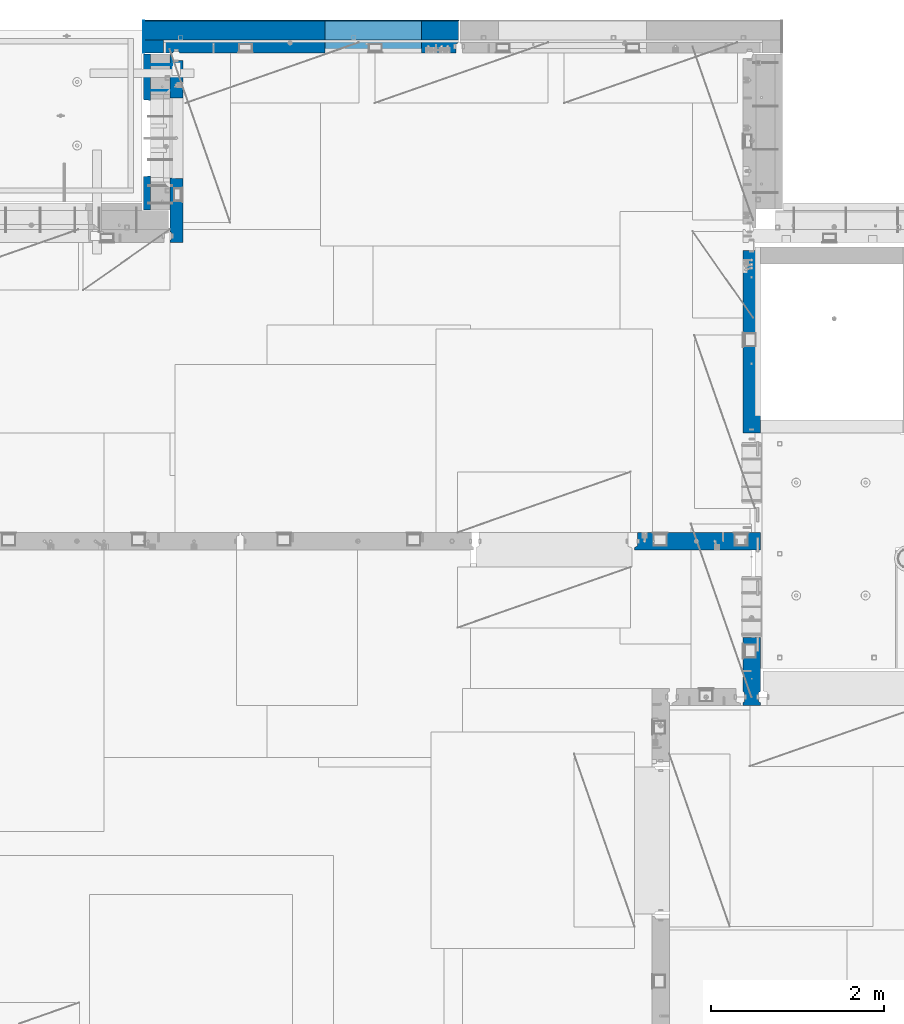
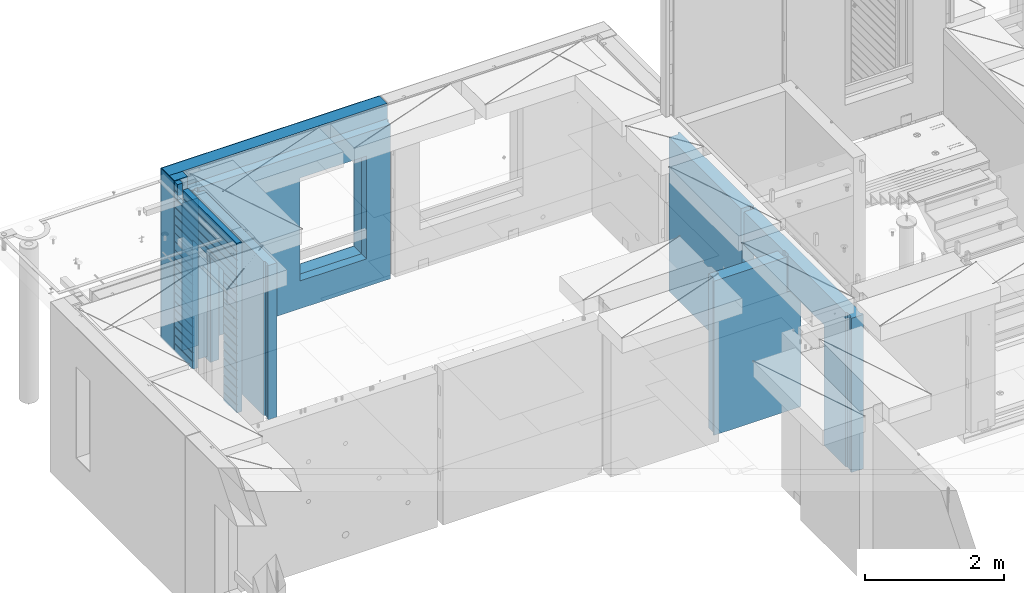
# One storey, part 237 of 352: 12 walls, 5 elements without a shape of their own.
"""IFC2X3 building model written with IfcOpenShell, lengths in millimetres."""

import ifcopenshell
import ifcopenshell.guid

model = None  # the IFC model being written
_history = None  # IfcOwnerHistory: only IFC2X3 demands one
_inside = {}  # id of a spatial element -> (the spatial element, [elements in it])
_under = {}  # id of a project, library or spatial element -> (it, [spatial elements below it])
_declared = {}  # id of a project -> (the project, [libraries it declares])
_typed = {}  # id of a type object -> (the type object, [elements of that type])
_made_of = {}  # id of a material, layer set ... -> (it, [elements and type objects made of it])


def new_model(schema):
    """Start an empty IFC model of exactly this schema.

    Asked for "IFC4X3", IfcOpenShell would pick the latest addendum, in which some entities
    have other attributes; the version numbers below select the first issue.
    IFC2X3 requires an IfcOwnerHistory on every rooted entity: one is made here for all.
    """
    global model, _history
    if schema == "IFC4X3":
        model = ifcopenshell.file(schema_version=(4, 3, 0, 0))
    else:
        model = ifcopenshell.file(schema=schema)
    _inside.clear()
    _under.clear()
    _declared.clear()
    _typed.clear()
    _made_of.clear()
    _history = None
    if model.schema == "IFC2X3":
        org = make("IfcOrganization", Name="unknown")
        user = make(
            "IfcPersonAndOrganization",
            ThePerson=make("IfcPerson", FamilyName="unknown"),
            TheOrganization=org,
        )
        app = make(
            "IfcApplication",
            ApplicationDeveloper=org,
            Version="unknown",
            ApplicationFullName="unknown",
            ApplicationIdentifier="unknown",
        )
        _history = make(
            "IfcOwnerHistory",
            OwningUser=user,
            OwningApplication=app,
            ChangeAction="ADDED",
            CreationDate=0,
        )
    return model


def make(cls, **values):
    """One entity of the class cls with the attributes given. An attribute that is None is left unset."""
    return model.create_entity(
        cls, **{name: value for name, value in values.items() if value is not None}
    )


def rooted(cls, **values):
    """An entity with a GlobalId (a new one), such as an element, a storey or a relation."""
    return make(cls, GlobalId=ifcopenshell.guid.new(), OwnerHistory=_history, **values)


def si_unit(unit_type, name, prefix=None):
    """IfcSIUnit, for example si_unit("LENGTHUNIT", "METRE", prefix="MILLI")."""
    return make("IfcSIUnit", UnitType=unit_type, Prefix=prefix, Name=name)


def assignment(units):
    """IfcUnitAssignment: the units of a project."""
    return None if units is None else make("IfcUnitAssignment", Units=units)


def point(xyz):
    """IfcCartesianPoint."""
    return None if xyz is None else make("IfcCartesianPoint", Coordinates=xyz)


def direction(xyz):
    """IfcDirection."""
    return None if xyz is None else make("IfcDirection", DirectionRatios=xyz)


def frame(location, z_axis=None, x_axis=None):
    """IfcAxis2Placement3D, a coordinate frame: its origin and axes. An axis left out is left unset."""
    return make(
        "IfcAxis2Placement3D",
        Location=point(location),
        Axis=direction(z_axis),
        RefDirection=direction(x_axis),
    )


def origin_with_axes():
    """The frame at (0, 0, 0) with the z axis (0, 0, 1) and the x axis (1, 0, 0) written out."""
    return frame((0.0, 0.0, 0.0), z_axis=(0.0, 0.0, 1.0), x_axis=(1.0, 0.0, 0.0))


def place(relative_to, where):
    """IfcLocalPlacement: puts the frame where relative to a parent placement (None: the world)."""
    return make(
        "IfcLocalPlacement", PlacementRelTo=relative_to, RelativePlacement=where
    )


def context(
    kind, dimensions, precision=None, world=None, true_north=None, identifier=None
):
    """IfcGeometricRepresentationContext, for example the 3D "Model" context."""
    return make(
        "IfcGeometricRepresentationContext",
        ContextIdentifier=identifier,
        ContextType=kind,
        CoordinateSpaceDimension=dimensions,
        Precision=precision,
        WorldCoordinateSystem=world,
        TrueNorth=true_north,
    )


def subcontext(parent, identifier, kind, view, scale=None):
    """IfcGeometricRepresentationSubContext, for example "Body" below "Model"."""
    return make(
        "IfcGeometricRepresentationSubContext",
        ContextIdentifier=identifier,
        ContextType=kind,
        ParentContext=parent,
        TargetScale=scale,
        TargetView=view,
    )


def project(units=None, contexts=None):
    """IfcProject with its units and contexts."""
    return rooted(
        "IfcProject",
        Name="project",
        RepresentationContexts=contexts,
        UnitsInContext=assignment(units),
    )


def spatial(cls, under=None, at=None, **own):
    """A site, building, storey or space (cls), placed at a placement, below another one or the project."""
    s = rooted(cls, ObjectPlacement=at, **own)
    if under is not None:
        _under.setdefault(under.id(), (under, []))[1].append(s)
    return s


def faces_of(points, faces, orient=None, outer=None):
    """IfcFace entities. A face is a list of loops; a loop is a list of indices into points, from 0.

    orient and outer hold one flag for each loop. By default every Orientation is true, the
    first loop of a face is its IfcFaceOuterBound and the others are IfcFaceBound.
    """
    made = []
    for i, loops in enumerate(faces):
        bounds = []
        for j, loop in enumerate(loops):
            is_outer = j == 0 if outer is None else outer[i][j]
            bounds.append(
                make(
                    "IfcFaceOuterBound" if is_outer else "IfcFaceBound",
                    Bound=make("IfcPolyLoop", Polygon=[points[k] for k in loop]),
                    Orientation=True if orient is None else orient[i][j],
                )
            )
        made.append(make("IfcFace", Bounds=bounds))
    return made


def faceted_brep(points, faces, orient=None, outer=None, voids=None):
    """IfcFacetedBrep: a solid bounded by flat faces; with voids (closed shells), ...WithVoids."""
    shared = [point(p) for p in points]
    hull = make("IfcClosedShell", CfsFaces=faces_of(shared, faces, orient, outer))
    if voids is None:
        return make("IfcFacetedBrep", Outer=hull)
    return make(
        "IfcFacetedBrepWithVoids",
        Outer=hull,
        Voids=[
            make(cls, CfsFaces=faces_of(shared, fs, o, b)) for cls, fs, o, b in voids
        ],
    )


def shape(context_of_items, identifier, shape_type, items):
    """IfcShapeRepresentation: the items that make up one representation, for example the "Body"."""
    return make(
        "IfcShapeRepresentation",
        ContextOfItems=context_of_items,
        RepresentationIdentifier=identifier,
        RepresentationType=shape_type,
        Items=items,
    )


def material(Name=None, Category=None):
    """IfcMaterial."""
    return make("IfcMaterial", Name=Name, Category=Category)


def made_of(thing, what):
    """Note that an element or type object is made of a material, layer set ...; save() writes the relation."""
    if what is not None:
        _made_of.setdefault(what.id(), (what, []))[1].append(thing)
    return thing


def type_object(cls, material=None, **own):
    """A type object (cls), such as IfcWallType, which elements share."""
    return made_of(rooted(cls, **own), material)


def element(
    cls,
    number,
    at=None,
    inside=None,
    cuts=None,
    type_object=None,
    material=None,
    context=None,
    identifier="Body",
    shape_type=None,
    held_by="IfcProductDefinitionShape",
    body=None,
    shapes=None,
    **own,
):
    """One element of the class cls, such as IfcWall. Its Tag is "e" and its number.

    at: its placement. inside: the storey or other place that contains it. cuts: it is an
    opening in that element (IfcRelVoidsElement). A single representation is given by context,
    identifier, shape_type and body (its items); several are given by shapes. held_by: the class
    of the entity that holds the representations. save() writes the other relations.
    """
    e = rooted(cls, Tag="e%d" % number, ObjectPlacement=at, **own)
    if body is not None:
        shapes = [shape(context, identifier, shape_type, body)]
    if shapes is not None:
        e.Representation = make(held_by, Representations=shapes)
    if inside is not None:
        _inside.setdefault(inside.id(), (inside, []))[1].append(e)
    if cuts is not None:
        rooted(
            "IfcRelVoidsElement", RelatingBuildingElement=cuts, RelatedOpeningElement=e
        )
    if type_object is not None:
        _typed.setdefault(type_object.id(), (type_object, []))[1].append(e)
    return made_of(e, material)


def aggregate(whole, parts):
    """IfcRelAggregates: a whole, such as a stair, and the parts it consists of."""
    return rooted("IfcRelAggregates", RelatingObject=whole, RelatedObjects=parts)


def save(model, path):
    """Write the relations noted so far, then the file.

    IfcRelAggregates (storeys below a building ...), IfcRelContainedInSpatialStructure (elements
    in a storey), IfcRelDefinesByType, IfcRelAssociatesMaterial and IfcRelDeclares: one each for
    every whole, place, type object, material and project.
    """
    for whole, parts in _under.values():
        aggregate(whole, parts)
    for where, things in _inside.values():
        rooted(
            "IfcRelContainedInSpatialStructure",
            RelatedElements=things,
            RelatingStructure=where,
        )
    for kind, things in _typed.values():
        rooted("IfcRelDefinesByType", RelatedObjects=things, RelatingType=kind)
    for what, things in _made_of.values():
        rooted("IfcRelAssociatesMaterial", RelatedObjects=things, RelatingMaterial=what)
    for by, libraries in _declared.values():
        rooted("IfcRelDeclares", RelatingContext=by, RelatedDefinitions=libraries)
    model.write(path)


model = new_model("IFC2X3")

# Units and contexts
model_context = context("Model", 3, precision=1e-05, world=origin_with_axes())
body_context = subcontext(model_context, "Body", "Model", "MODEL_VIEW")
ifc_project = project(units=[si_unit("LENGTHUNIT", "METRE", prefix="MILLI"), si_unit("AREAUNIT", "SQUARE_METRE"), si_unit("VOLUMEUNIT", "CUBIC_METRE"), si_unit("MASSUNIT", "GRAM", prefix="KILO"), si_unit("TIMEUNIT", "SECOND"), si_unit("PLANEANGLEUNIT", "RADIAN"), si_unit("SOLIDANGLEUNIT", "STERADIAN"), si_unit("THERMODYNAMICTEMPERATUREUNIT", "DEGREE_CELSIUS"), si_unit("LUMINOUSINTENSITYUNIT", "LUMEN")], contexts=[model_context])

# Site, building, storey
site_placement = place(None, origin_with_axes())
site = spatial("IfcSite", under=ifc_project, at=site_placement, CompositionType="ELEMENT")
building_placement = place(site_placement, origin_with_axes())
building = spatial("IfcBuilding", under=site, at=building_placement, CompositionType="ELEMENT")
storey_placement = place(building_placement, origin_with_axes())
storey = spatial("IfcBuildingStorey", under=building, at=storey_placement, Name="6", CompositionType="ELEMENT", Elevation=0.0)

# Assembly, walls
assembly_1_placement = place(storey_placement, origin_with_axes())
assembly_1 = element("IfcElementAssembly", 1, at=assembly_1_placement, inside=storey, AssemblyPlace="NOTDEFINED", PredefinedType="REINFORCEMENT_UNIT")
ifc_material_1 = material(Name="Undefined")
wall_type_1 = type_object("IfcWallType", PredefinedType="NOTDEFINED")
wall_1_placement = place(assembly_1_placement, frame((11020.0, 22485.0002441406, 98115.0), z_axis=(0.0, 0.0, 1.0), x_axis=(-1.0, 3.00000001838171e-08, 0.0)))
wall_1 = element("IfcWall", 2, at=wall_1_placement, type_object=wall_type_1, material=ifc_material_1, Name="(PD)", context=body_context, shape_type="Brep", body=[
    faceted_brep([(0.0, 5.0, -1300.0), (0.0, 5.0, 1300.0), (280.0, 5.0, 1300.0), (280.0, 5.0, -1300.0), (0.0, -5.0, 1300.0), (280.0, -5.0, 1300.0), (0.0, -5.0, -1300.0), (280.0, -5.0, -1300.0)], [[[0, 1, 2, 3]], [[1, 4, 5, 2]], [[4, 6, 7, 5]], [[6, 0, 3, 7]], [[5, 7, 3, 2]], [[6, 4, 1, 0]]]),
])
wall_2_placement = place(assembly_1_placement, frame((11020.0, 22185.0002441406, 98115.0), z_axis=(0.0, 0.0, 1.0), x_axis=(-1.0, 3.00000001838171e-08, 0.0)))
wall_2 = element("IfcWall", 3, at=wall_2_placement, type_object=wall_type_1, material=ifc_material_1, Name="(PD)", context=body_context, shape_type="Brep", body=[
    faceted_brep([(0.0, 5.0, -1300.0), (0.0, 5.0, 1300.0), (280.0, 5.0, 1300.0), (280.0, 5.0, -1300.0), (0.0, -5.0, 1300.0), (280.0, -5.0, 1300.0), (0.0, -5.0, -1300.0), (280.0, -5.0, -1300.0)], [[[0, 1, 2, 3]], [[1, 4, 5, 2]], [[4, 6, 7, 5]], [[6, 0, 3, 7]], [[5, 7, 3, 2]], [[6, 4, 1, 0]]]),
])

# Assembly, wall
assembly_2_placement = place(storey_placement, origin_with_axes())
assembly_2 = element("IfcElementAssembly", 4, at=assembly_2_placement, inside=storey, AssemblyPlace="NOTDEFINED", PredefinedType="REINFORCEMENT_UNIT")
ifc_material_2 = material(Name="CONCRETE/C25/30")
wall_type_2 = type_object("IfcWallType", PredefinedType="NOTDEFINED")
wall_3_placement = place(assembly_2_placement, frame((17710.0, 18214.9992663657, 98112.5), z_axis=(0.0, 0.0, 1.0), x_axis=(0.0, 1.0, 0.0)))
wall_3 = element("IfcWall", 5, at=wall_3_placement, type_object=wall_type_2, material=ifc_material_2, context=body_context, shape_type="Brep", body=[
    faceted_brep([(2120.00073363433, -57.0000000000036, 1357.5), (2120.00073363433, -57.0000000000036, -1357.5), (2120.00073363433, 100.0, -1357.5), (2120.00073363433, 100.0, 1357.5), (2165.00073363433, -70.0000000000036, 1357.5), (2165.00073363433, -70.0000000000036, -1357.5), (45.0, 100.0, 1357.5), (45.0, 100.0, 762.5), (45.0, -57.0, 762.5), (45.0, -57.0, 1357.5), (15.0, -70.0, 762.5), (15.0, 100.0, 762.5), (15.0, -70.0, 1357.5), (15.0, 100.0, -1357.5), (15.0, -100.0, -1357.5), (15.0, -100.0, 1357.5), (2165.00073363433, -100.0, -1357.5), (2165.00073363433, -100.0, 1357.5)], [[[0, 1, 2, 3]], [[4, 5, 1, 0]], [[6, 7, 8, 9]], [[10, 8, 7, 11]], [[12, 9, 8, 10]], [[11, 13, 14, 15, 12, 10]], [[15, 14, 16, 17]], [[3, 6, 9, 12, 15, 17, 4, 0]], [[13, 11, 7, 6, 3, 2]], [[16, 14, 13, 2, 1, 5]], [[17, 16, 5, 4]]]),
])
aggregate(assembly_2, [wall_3])

assembly_3_placement = place(storey_placement, origin_with_axes())
assembly_3 = element("IfcElementAssembly", 6, at=assembly_3_placement, inside=storey, AssemblyPlace="NOTDEFINED", PredefinedType="REINFORCEMENT_UNIT")
wall_4_placement = place(assembly_3_placement, frame((17710.0, 15080.0, 98112.5), z_axis=(0.0, 0.0, 1.0), x_axis=(0.0, 1.0, 0.0)))
wall_4 = element("IfcWall", 7, at=wall_4_placement, type_object=wall_type_2, material=ifc_material_2, context=body_context, shape_type="Brep", body=[
    faceted_brep([(3089.99926636568, -57.0, 1357.5), (3089.99926636568, -57.0, 762.5), (3089.99926620436, 100.0, 762.5), (3089.99926636568, 100.0, 1357.5), (3119.99926636568, -70.0, 1357.5), (3119.99926636568, -69.9999995451544, 762.5), (1965.00000368528, 100.0, 1357.5), (1965.00000368528, 99.9999997455598, 762.5), (1951.9999991369, 80.0000000823711, 762.5), (1951.9999991369, 80.0000000823711, 1357.5), (1848.00000041054, 79.9999993903439, 762.5), (1848.00000041054, 79.9999993903439, 1357.5), (1835.0, 100.0, 762.5), (1835.0, 100.0, 1357.5), (790.003238525391, -100.0, -1357.5), (790.003238525391, 100.0, -1357.5), (790.003238525391, 100.0, 762.5), (790.003238525391, -100.0, 762.5), (164.999999999998, 100.0, -1357.5), (164.999999999996, 100.0, 1357.5), (47.9997742438973, -79.9991481948964, 1357.5), (47.9997742438991, -79.9991481948928, -1357.5), (152.000000457021, -79.9991466091124, -1357.5), (152.000000457019, -79.9991466091124, 1357.5), (34.9997701872417, -100.0, 1357.5), (34.9997701872435, -100.0, -1357.5), (0.0, -100.0, 1357.5), (0.0, -100.0, -1357.5), (0.0, 100.0, 1357.5), (0.0, 100.0, -1357.5), (35.0, 100.0, 1357.5), (35.0, 100.0, -1357.5), (48.0, 80.0, 1357.5), (48.0, 80.0, -1357.5), (152.0, 80.0, 1357.5), (152.0, 80.0, -1357.5), (165.0, -100.0, -1357.5), (164.999999999998, -99.9991455078125, 1357.5), (3119.99926636568, -100.0, 762.5), (3119.99926636568, -100.0, 1357.5)], [[[0, 1, 2, 3]], [[4, 5, 1, 0]], [[6, 7, 8, 9]], [[9, 8, 10, 11]], [[11, 10, 12, 13]], [[14, 15, 16, 17]], [[13, 12, 16, 15, 18, 19]], [[20, 21, 22, 23]], [[24, 25, 21, 20]], [[26, 27, 25, 24]], [[27, 26, 28, 29]], [[29, 28, 30, 31]], [[32, 33, 31, 30]], [[34, 35, 33, 32]], [[19, 18, 35, 34]], [[15, 14, 36, 22, 21, 25, 27, 29, 31, 33, 35, 18]], [[37, 23, 22, 36]], [[14, 17, 38, 39, 37, 36]], [[13, 19, 34, 32, 30, 28, 26, 24, 20, 23, 37, 39, 4, 0, 3, 6, 9, 11]], [[7, 6, 3, 2]], [[38, 17, 16, 12, 10, 8, 7, 2, 1, 5]], [[39, 38, 5, 4]]]),
])
aggregate(assembly_3, [wall_4])

assembly_4_placement = place(storey_placement, origin_with_axes())
assembly_4 = element("IfcElementAssembly", 8, at=assembly_4_placement, inside=storey, AssemblyPlace="NOTDEFINED", PredefinedType="REINFORCEMENT_UNIT")
wall_5_placement = place(assembly_4_placement, frame((16359.9991042544, 16980.0, 98112.5), z_axis=(0.0, 0.0, 1.0), x_axis=(1.0, 0.0, 0.0)))
wall_5 = element("IfcWall", 9, at=wall_5_placement, type_object=wall_type_2, material=ifc_material_2, context=body_context, shape_type="Brep", body=[
    faceted_brep([(1185.00089736511, 100.0, 1357.5), (1185.00089574558, -57.0, 1357.5), (1185.00089574558, -57.0, 742.5), (1185.00089736511, 99.9999999278843, 742.5), (1220.00089574558, -70.2708332915754, 1357.5), (1220.00089574558, -70.270833291579, 742.5), (1220.00089574558, 100.000001967095, 742.5), (0.0, -100.0, -1357.5), (0.0, -100.0, 1357.5), (0.0, -70.0000178764712, 1357.5), (0.0, -70.0000178764712, -1357.5), (30.0000412533973, -57.0, 1357.5), (30.0000412533973, -57.0, -1357.5), (30.0000000000009, 100.0, 1357.5), (30.0, 100.0, -1357.5), (1450.0, 100.0, -1357.5), (1450.0, -100.0, -1357.5), (1450.00089574558, 100.0, 742.5), (1450.0, -100.0, 742.5), (1220.00089574558, -100.0, 1357.5), (1220.00089574558, -100.0, 742.5), (1225.00089532057, 100.0, 742.5)], [[[0, 1, 2, 3]], [[4, 5, 2, 1]], [[6, 3, 2, 5]], [[7, 8, 9, 10]], [[11, 12, 10, 9]], [[13, 14, 12, 11]], [[15, 16, 7, 10, 12, 14]], [[16, 15, 17, 18]], [[19, 8, 7, 16, 18, 20]], [[17, 21, 6, 5, 20, 18]], [[19, 20, 5, 4]], [[0, 13, 11, 9, 8, 19, 4, 1]], [[21, 17, 15, 14, 13, 0, 3, 6]]]),
])
aggregate(assembly_4, [wall_5])

# Assembly, walls
assembly_5_placement = place(storey_placement, origin_with_axes())
assembly_5 = element("IfcElementAssembly", 10, at=assembly_5_placement, inside=storey, AssemblyPlace="NOTDEFINED", PredefinedType="REINFORCEMENT_UNIT")
ifc_material_3 = material()
wall_type_3 = type_object("IfcWallType", PredefinedType="NOTDEFINED")
wall_6_placement = place(assembly_5_placement, frame((10805.0, 22620.0, 98247.5), z_axis=(0.0, 0.0, 1.0), x_axis=(0.0, 1.0, 0.0)))
wall_6 = element("IfcWall", 11, at=wall_6_placement, type_object=wall_type_3, material=ifc_material_3, context=body_context, shape_type="Brep", body=[
    faceted_brep([(0.0, 110.0, -1492.5), (0.0, 110.0, 1492.5), (150.0, 110.0, 1492.5), (150.0, 110.0, -1492.5), (0.0, -110.0, 1492.5), (150.0, -110.0, 1492.5), (0.0, -110.0, -1492.5), (150.0, -110.0, -1492.5)], [[[0, 1, 2, 3]], [[1, 4, 5, 2]], [[4, 6, 7, 5]], [[6, 0, 3, 7]], [[5, 7, 3, 2]], [[6, 4, 1, 0]]]),
])
wall_7_placement = place(assembly_5_placement, frame((10915.0, 22880.0, 98247.5), z_axis=(0.0, 0.0, 1.0), x_axis=(1.0, 0.0, 0.0)))
wall_7 = element("IfcWall", 12, at=wall_7_placement, type_object=wall_type_3, material=ifc_material_3, context=body_context, shape_type="Brep", body=[
    faceted_brep([(-220.0, -110.0, -1492.5), (-220.0, 110.0, -1492.5), (3410.0, 110.0, -1492.5), (3410.0, -110.0, -1492.5), (-220.0, -110.0, 1492.5), (-220.0, 110.0, 1492.5), (3410.0, -110.0, 1492.5), (3410.0, 110.0, 1492.5), (1869.99971073172, 110.0, -1002.5), (2979.99971073172, 110.0, -1002.5), (2979.99971073172, 110.0, 807.5), (1869.99971073172, 110.0, 807.5), (1869.99971073172, -110.0, -1002.5), (1869.99971073172, -110.0, 807.5), (2979.99971073172, -110.0, 807.5), (2979.99971073172, -110.0, -1002.5)], [[[0, 1, 2, 3]], [[0, 4, 5, 1]], [[5, 4, 6, 7]], [[1, 5, 7, 2], [8, 9, 10, 11]], [[6, 3, 2, 7]], [[4, 0, 3, 6], [12, 13, 14, 15]], [[10, 14, 13, 11]], [[9, 15, 14, 10]], [[8, 12, 15, 9]], [[11, 13, 12, 8]]]),
])

# Wall
ifc_material_4 = material(Name="CONCRETE/C30/37")
wall_type_4 = type_object("IfcWallType", PredefinedType="NOTDEFINED")
wall_8_placement = place(assembly_1_placement, frame((10727.5, 20805.0, 98247.5), z_axis=(0.0, 0.0, 1.0), x_axis=(0.0, 1.0, 0.0)))
wall_8 = element("IfcWall", 13, at=wall_8_placement, type_object=wall_type_4, material=ifc_material_4, context=body_context, shape_type="Brep", body=[
    faceted_brep([(1800.0, -42.5, 1492.5), (1800.0, 42.5, 1492.5), (1705.0, 42.5, 1492.5), (1705.0, -42.5, 1492.5), (0.0, 42.5, -1492.5), (0.0, 42.5, -1357.00000005524), (384.998212827581, 42.5, -1357.00000005524), (384.998212827581, 42.5, -1492.5), (0.0, 32.4999992507037, -1355.00000000074), (386.174879582417, 32.4999992506928, -1355.0000000008), (0.0, 32.4999991127006, -1344.99999959956), (386.174879598653, 32.4999991126915, -1344.99999959957), (0.0, 42.5, -1343.00000011075), (384.998212827581, 42.5, -1343.00000011075), (0.0, 42.5, -1207.00000005524), (384.998212827581, 42.5, -1207.00000005524), (0.0, 32.4999992507037, -1205.00000000074), (386.174879582417, 32.4999992506928, -1205.0000000008), (0.0, 32.4999991127006, -1194.99999959956), (386.174879598653, 32.4999991126915, -1194.99999959957), (0.0, 42.5, -1193.00000011075), (384.998212827581, 42.5, -1193.00000011075), (0.0, 42.5, -1057.00000005524), (384.998212827581, 42.5, -1057.00000005524), (0.0, 32.4999992507037, -1055.00000000074), (386.174879582417, 32.4999992506928, -1055.0000000008), (0.0, 32.4999991127006, -1044.99999959956), (386.174879598653, 32.4999991126915, -1044.99999959957), (0.0, 42.5, -1043.00000011075), (384.998212827581, 42.5, -1043.00000011075), (0.0, 42.5, -907.000000055239), (384.998212827581, 42.5, -907.000000055239), (0.0, 32.4999992507037, -905.000000000742), (386.174879582417, 32.4999992506928, -905.0000000008), (0.0, 32.4999991127006, -894.99999959956), (386.174879598653, 32.4999991126915, -894.999999599575), (0.0, 42.5, -893.000000110755), (384.998212827581, 42.5, -893.000000110755), (0.0, 42.5, -757.000000055239), (384.998212827581, 42.5, -757.000000055239), (0.0, 32.4999992507037, -755.000000000742), (386.174879582417, 32.4999992506928, -755.0000000008), (0.0, 32.4999991127006, -744.99999959956), (386.174879598653, 32.4999991126915, -744.999999599575), (0.0, 42.5, -743.000000110755), (384.998212827581, 42.5, -743.000000110755), (0.0, 42.5, -607.000000055239), (384.998212827581, 42.5, -607.000000055239), (3.63797880709171e-12, 32.4999992507037, -605.000000000742), (386.174879582417, 32.4999992506928, -605.0000000008), (3.63797880709171e-12, 32.4999991127006, -594.99999959956), (386.174879598653, 32.4999991126915, -594.999999599575), (0.0, 42.5, -593.000000110755), (384.998212827581, 42.5, -593.000000110755), (0.0, 42.5, -457.000000055239), (384.998212827581, 42.5, -457.000000055239), (0.0, 32.4999992507037, -455.000000000742), (386.174879582417, 32.4999992506928, -455.0000000008), (0.0, 32.4999991127006, -444.99999959956), (386.174879598653, 32.4999991126915, -444.999999599575), (0.0, 42.5, -443.000000110755), (384.998212827581, 42.5, -443.000000110755), (0.0, 42.5, -307.000000055239), (384.998212827581, 42.5, -307.000000055239), (0.0, 32.4999992507037, -305.000000000742), (386.174879582417, 32.4999992506928, -305.0000000008), (0.0, 32.4999991127006, -294.99999959956), (386.174879598653, 32.4999991126915, -294.999999599575), (0.0, 42.5, -293.000000110755), (384.998212827581, 42.5, -293.000000110755), (0.0, 42.5, -157.000000055239), (384.998212827581, 42.5, -157.000000055239), (3.63797880709171e-12, 32.4999992507037, -155.000000000742), (386.174879582417, 32.4999992506928, -155.0000000008), (3.63797880709171e-12, 32.4999991127006, -144.99999959956), (386.174879598653, 32.4999991126915, -144.999999599575), (0.0, 42.5, -143.000000110755), (384.998212827581, 42.5, -143.000000110755), (0.0, 42.5, -7.00000005523907), (384.998212827581, 42.5, -7.00000005523907), (0.0, 32.4999992507037, -5.00000000074215), (386.174879582417, 32.4999992506928, -5.00000000080036), (0.0, 32.4999991127006, 5.0000004004396), (386.174879598653, 32.4999991126915, 5.00000040042505), (0.0, 42.5, 6.99999988924537), (384.998212827581, 42.5, 6.99999988924537), (0.0, 42.5, 142.999999944761), (384.998212827581, 42.5, 142.999999944761), (-3.63797880709171e-12, 32.4999992507037, 144.999999999258), (386.174879582417, 32.4999992506928, 144.9999999992), (-3.63797880709171e-12, 32.4999991127006, 155.00000040044), (386.174879598653, 32.4999991126915, 155.000000400425), (0.0, 42.5, 156.999999889245), (384.998212827581, 42.5, 156.999999889245), (0.0, 42.5, 292.999999944761), (384.998212827581, 42.5, 292.999999944761), (-3.63797880709171e-12, 32.4999992507037, 294.999999999258), (386.174879582417, 32.4999992506928, 294.9999999992), (-3.63797880709171e-12, 32.4999991127006, 305.00000040044), (386.174879598653, 32.4999991126915, 305.000000400425), (0.0, 42.5, 306.999999889245), (384.998212827581, 42.5, 306.999999889245), (0.0, 42.5, 442.999999944761), (384.998212827581, 42.5, 442.999999944761), (0.0, 32.4999992507037, 444.999999999258), (386.174879582417, 32.4999992506928, 444.9999999992), (0.0, 32.4999991127006, 455.00000040044), (386.174879598653, 32.4999991126915, 455.000000400425), (0.0, 42.5, 456.999999889245), (384.998212827581, 42.5, 456.999999889245), (0.0, 42.5, 592.999999944761), (384.998212827581, 42.5, 592.999999944761), (3.63797880709171e-12, 32.4999992507037, 594.999999999258), (386.174879582417, 32.4999992506928, 594.9999999992), (3.63797880709171e-12, 32.4999991127006, 605.00000040044), (386.174879598653, 32.4999991126915, 605.000000400425), (0.0, 42.5, 606.999999889245), (384.998212827581, 42.5, 606.999999889245), (0.0, 42.5, 742.999999944761), (384.998212827581, 42.5, 742.999999944761), (0.0, 32.4999992507037, 744.999999999258), (386.174879582417, 32.4999992506928, 744.9999999992), (0.0, 32.4999991127006, 755.00000040044), (386.174879598653, 32.4999991126915, 755.000000400425), (0.0, 42.5, 756.999999889245), (384.998212827581, 42.5, 756.999999889245), (0.0, 42.5, 1206.99999988925), (1800.0, 42.5, 1206.99999988925), (1800.0, 32.4999991126897, 1205.00000040043), (0.0, 32.4999991127006, 1205.00000040044), (1800.0, 32.4999992507001, 1194.99999999923), (0.0, 32.4999992507037, 1194.99999999926), (0.0, 42.5, 1192.99999994476), (1800.0, 42.5, 1192.99999994476), (1800.0, 42.5, 1056.99999988925), (0.0, 42.5, 1056.99999988925), (1800.0, 32.4999991126897, 1055.00000040043), (0.0, 32.4999991127006, 1055.00000040044), (1800.0, 32.4999992507001, 1044.99999999923), (0.0, 32.4999992507037, 1044.99999999926), (0.0, 42.5, 1042.99999994476), (1800.0, 42.5, 1042.99999994476), (1800.0, 42.5, 906.999999889245), (0.0, 42.5, 906.999999889245), (1800.0, 32.4999991126897, 905.000000400425), (0.0, 32.4999991127006, 905.00000040044), (1800.0, 32.4999992507001, 894.999999999229), (0.0, 32.4999992507037, 894.999999999258), (0.0, 42.5, 892.999999944761), (1800.0, 42.5, 892.999999944761), (1800.0, 42.5, -1357.00000005524), (1800.0, 42.5, -1492.5), (1274.99821282758, 42.5, -1492.5), (1274.99821282758, 42.5, -1357.00000005524), (1800.0, 32.4999992507001, -1355.00000000077), (1273.82154607274, 32.4999992506928, -1355.0000000008), (1800.0, 32.4999991126897, -1344.99999959957), (1273.82154605651, 32.4999991126915, -1344.99999959957), (1800.0, 42.5, -1343.00000011075), (1274.99821282758, 42.5, -1343.00000011075), (1800.0, 42.5, -1207.00000005524), (1274.99821282758, 42.5, -1207.00000005524), (1800.0, 32.4999992507001, -1205.00000000077), (1273.82154607274, 32.4999992506928, -1205.0000000008), (1800.0, 32.4999991126897, -1194.99999959957), (1273.82154605651, 32.4999991126915, -1194.99999959957), (1800.0, 42.5, -1193.00000011075), (1274.99821282758, 42.5, -1193.00000011075), (1800.0, 42.5, -1057.00000005524), (1274.99821282758, 42.5, -1057.00000005524), (1800.0, 32.4999992507001, -1055.00000000077), (1273.82154607274, 32.4999992506928, -1055.0000000008), (1800.0, 32.4999991126897, -1044.99999959957), (1273.82154605651, 32.4999991126915, -1044.99999959957), (1800.0, 42.5, -1043.00000011075), (1274.99821282758, 42.5, -1043.00000011075), (1800.0, 42.5, -907.000000055239), (1274.99821282758, 42.5, -907.000000055239), (1800.0, 32.4999992507001, -905.000000000771), (1273.82154607274, 32.4999992506928, -905.0000000008), (1800.0, 32.4999991126897, -894.999999599575), (1273.82154605651, 32.4999991126915, -894.999999599575), (1800.0, 42.5, -893.000000110755), (1274.99821282758, 42.5, -893.000000110755), (1800.0, 42.5, -757.000000055239), (1274.99821282758, 42.5, -757.000000055239), (1800.0, 32.4999992507001, -755.000000000771), (1273.82154607274, 32.4999992506928, -755.0000000008), (1800.0, 32.4999991126897, -744.999999599575), (1273.82154605651, 32.4999991126915, -744.999999599575), (1800.0, 42.5, -743.000000110755), (1274.99821282758, 42.5, -743.000000110755), (1800.0, 42.5, -607.000000055239), (1274.99821282758, 42.5, -607.000000055239), (1800.0, 32.4999992507001, -605.000000000771), (1273.82154607274, 32.4999992506928, -605.0000000008), (1800.0, 32.4999991126897, -594.999999599575), (1273.82154605651, 32.4999991126915, -594.999999599575), (1800.0, 42.5, -593.000000110755), (1274.99821282758, 42.5, -593.000000110755), (1800.0, 42.5, -457.000000055239), (1274.99821282758, 42.5, -457.000000055239), (1800.0, 32.4999992507001, -455.000000000771), (1273.82154607274, 32.4999992506928, -455.0000000008), (1800.0, 32.4999991126897, -444.999999599575), (1273.82154605651, 32.4999991126915, -444.999999599575), (1800.0, 42.5, -443.000000110755), (1274.99821282758, 42.5, -443.000000110755), (1800.0, 42.5, -307.000000055239), (1274.99821282758, 42.5, -307.000000055239), (1800.0, 32.4999992507001, -305.000000000771), (1273.82154607274, 32.4999992506928, -305.0000000008), (1800.0, 32.4999991126897, -294.999999599575), (1273.82154605651, 32.4999991126915, -294.999999599575), (1800.0, 42.5, -293.000000110755), (1274.99821282758, 42.5, -293.000000110755), (1800.0, 42.5, -157.000000055239), (1274.99821282758, 42.5, -157.000000055239), (1800.0, 32.4999992507001, -155.000000000771), (1273.82154607274, 32.4999992506928, -155.0000000008), (1800.0, 32.4999991126897, -144.999999599575), (1273.82154605651, 32.4999991126915, -144.999999599575), (1800.0, 42.5, -143.000000110755), (1274.99821282758, 42.5, -143.000000110755), (1800.0, 42.5, -7.00000005523907), (1274.99821282758, 42.5, -7.00000005523907), (1800.0, 32.4999992507001, -5.00000000077125), (1273.82154607274, 32.4999992506928, -5.00000000080036), (1800.0, 32.4999991126897, 5.00000040042505), (1273.82154605651, 32.4999991126915, 5.00000040042505), (1800.0, 42.5, 6.99999988924537), (1274.99821282758, 42.5, 6.99999988924537), (1800.0, 42.5, 142.999999944761), (1274.99821282758, 42.5, 142.999999944761), (1800.0, 32.4999992507001, 144.999999999229), (1273.82154607274, 32.4999992506928, 144.9999999992), (1800.0, 32.4999991126897, 155.000000400425), (1273.82154605651, 32.4999991126915, 155.000000400425), (1800.0, 42.5, 156.999999889245), (1274.99821282758, 42.5, 156.999999889245), (1800.0, 42.5, 292.999999944761), (1274.99821282758, 42.5, 292.999999944761), (1800.0, 32.4999992507001, 294.999999999229), (1273.82154607274, 32.4999992506928, 294.9999999992), (1800.0, 32.4999991126897, 305.000000400425), (1273.82154605651, 32.4999991126915, 305.000000400425), (1800.0, 42.5, 306.999999889245), (1274.99821282758, 42.5, 306.999999889245), (1800.0, 42.5, 442.999999944761), (1274.99821282758, 42.5, 442.999999944761), (1800.0, 32.4999992507001, 444.999999999229), (1273.82154607274, 32.4999992506928, 444.9999999992), (1800.0, 32.4999991126897, 455.000000400425), (1273.82154605651, 32.4999991126915, 455.000000400425), (1800.0, 42.5, 456.999999889245), (1274.99821282758, 42.5, 456.999999889245), (1800.0, 42.5, 592.999999944761), (1274.99821282758, 42.5, 592.999999944761), (1800.0, 32.4999992507001, 594.999999999229), (1273.82154607274, 32.4999992506928, 594.9999999992), (1800.0, 32.4999991126897, 605.000000400425), (1273.82154605651, 32.4999991126915, 605.000000400425), (1800.0, 42.5, 606.999999889245), (1274.99821282758, 42.5, 606.999999889245), (1800.0, 42.5, 742.999999944761), (1274.99821282758, 42.5, 742.999999944761), (1800.0, 32.4999992507001, 744.999999999229), (1273.82154607274, 32.4999992506928, 744.9999999992), (1800.0, 32.4999991126897, 755.000000400425), (1273.82154605651, 32.4999991126915, 755.000000400425), (1800.0, 42.5, 756.999999889245), (1274.99821282758, 42.5, 756.999999889245), (395.000271651108, 42.5, 782.5), (384.998212827581, 42.5, 782.5), (1274.99821282758, 42.5, 782.5), (1265.00027165111, 42.5, 782.5), (394.999879494248, -42.5, 787.502857142856), (1264.99654616091, -42.5, 787.502857142856), (394.999879494248, -42.5, 782.5), (394.999879494248, -42.5, -1492.5), (0.0, -42.5, -1492.5), (-3.63797880709171e-12, 32.4999992507037, 1344.99999999926), (0.0, 42.5, 1342.99999994476), (0.0, -42.5, 1492.5), (0.0, 42.5, 1492.5), (0.0, 42.5, 1356.99999988925), (-3.63797880709171e-12, 32.4999991127006, 1355.00000040044), (1555.0, 42.5, 1356.99999988925), (1555.0, 32.4999991126915, 1355.00000040043), (1555.0, 32.4999992506928, 1344.9999999992), (1555.0, 42.5, 1342.99999994476), (1800.0, 42.5, 1342.99999994476), (1555.0, 42.5, 1222.5), (1705.0, 42.5, 1222.5), (1705.0, 42.5, 1343.0), (1800.0, 32.4999992507001, 1344.99999999923), (1705.0, 32.5, 1345.0), (1800.0, 32.4999991126897, 1355.00000040043), (1705.0, 32.5, 1355.0), (1800.0, 42.5, 1356.99999988925), (1705.0, 42.5, 1357.0), (1800.0, -42.5, -1492.5), (1264.99654616091, -42.5, -1492.5), (1264.99654616091, -42.5, 782.5), (1705.0, -42.5, 1222.5), (1555.0, -42.5, 1222.5), (1555.0, -42.5, 1492.5), (1555.0, 42.5, 1492.5)], [[[0, 1, 2, 3]], [[4, 5, 6, 7]], [[5, 8, 9, 6]], [[8, 10, 11, 9]], [[10, 12, 13, 11]], [[12, 14, 15, 13]], [[14, 16, 17, 15]], [[16, 18, 19, 17]], [[18, 20, 21, 19]], [[20, 22, 23, 21]], [[22, 24, 25, 23]], [[24, 26, 27, 25]], [[26, 28, 29, 27]], [[28, 30, 31, 29]], [[30, 32, 33, 31]], [[32, 34, 35, 33]], [[34, 36, 37, 35]], [[36, 38, 39, 37]], [[38, 40, 41, 39]], [[40, 42, 43, 41]], [[42, 44, 45, 43]], [[44, 46, 47, 45]], [[46, 48, 49, 47]], [[48, 50, 51, 49]], [[50, 52, 53, 51]], [[52, 54, 55, 53]], [[54, 56, 57, 55]], [[56, 58, 59, 57]], [[58, 60, 61, 59]], [[60, 62, 63, 61]], [[62, 64, 65, 63]], [[64, 66, 67, 65]], [[66, 68, 69, 67]], [[68, 70, 71, 69]], [[70, 72, 73, 71]], [[72, 74, 75, 73]], [[74, 76, 77, 75]], [[76, 78, 79, 77]], [[78, 80, 81, 79]], [[80, 82, 83, 81]], [[82, 84, 85, 83]], [[84, 86, 87, 85]], [[86, 88, 89, 87]], [[88, 90, 91, 89]], [[90, 92, 93, 91]], [[92, 94, 95, 93]], [[94, 96, 97, 95]], [[96, 98, 99, 97]], [[98, 100, 101, 99]], [[100, 102, 103, 101]], [[102, 104, 105, 103]], [[104, 106, 107, 105]], [[106, 108, 109, 107]], [[108, 110, 111, 109]], [[110, 112, 113, 111]], [[112, 114, 115, 113]], [[114, 116, 117, 115]], [[116, 118, 119, 117]], [[118, 120, 121, 119]], [[120, 122, 123, 121]], [[122, 124, 125, 123]], [[126, 127, 128, 129]], [[129, 128, 130, 131]], [[132, 131, 130, 133]], [[134, 135, 132, 133]], [[135, 134, 136, 137]], [[137, 136, 138, 139]], [[140, 139, 138, 141]], [[142, 143, 140, 141]], [[143, 142, 144, 145]], [[145, 144, 146, 147]], [[148, 147, 146, 149]], [[150, 151, 152, 153]], [[154, 150, 153, 155]], [[156, 154, 155, 157]], [[158, 156, 157, 159]], [[160, 158, 159, 161]], [[162, 160, 161, 163]], [[164, 162, 163, 165]], [[166, 164, 165, 167]], [[168, 166, 167, 169]], [[170, 168, 169, 171]], [[172, 170, 171, 173]], [[174, 172, 173, 175]], [[176, 174, 175, 177]], [[178, 176, 177, 179]], [[180, 178, 179, 181]], [[182, 180, 181, 183]], [[184, 182, 183, 185]], [[186, 184, 185, 187]], [[188, 186, 187, 189]], [[190, 188, 189, 191]], [[192, 190, 191, 193]], [[194, 192, 193, 195]], [[196, 194, 195, 197]], [[198, 196, 197, 199]], [[200, 198, 199, 201]], [[202, 200, 201, 203]], [[204, 202, 203, 205]], [[206, 204, 205, 207]], [[208, 206, 207, 209]], [[210, 208, 209, 211]], [[212, 210, 211, 213]], [[214, 212, 213, 215]], [[216, 214, 215, 217]], [[218, 216, 217, 219]], [[220, 218, 219, 221]], [[222, 220, 221, 223]], [[224, 222, 223, 225]], [[226, 224, 225, 227]], [[228, 226, 227, 229]], [[230, 228, 229, 231]], [[232, 230, 231, 233]], [[234, 232, 233, 235]], [[236, 234, 235, 237]], [[238, 236, 237, 239]], [[240, 238, 239, 241]], [[242, 240, 241, 243]], [[244, 242, 243, 245]], [[246, 244, 245, 247]], [[248, 246, 247, 249]], [[250, 248, 249, 251]], [[252, 250, 251, 253]], [[254, 252, 253, 255]], [[256, 254, 255, 257]], [[258, 256, 257, 259]], [[260, 258, 259, 261]], [[262, 260, 261, 263]], [[264, 262, 263, 265]], [[266, 264, 265, 267]], [[268, 266, 267, 269]], [[270, 268, 269, 271]], [[272, 273, 125, 124, 148, 149, 270, 271, 274, 275]], [[276, 273, 272, 275, 274, 277]], [[278, 279, 7, 6, 9, 11, 13, 15, 17, 19, 21, 23, 25, 27, 29, 31, 33, 35, 37, 39, 41, 43, 45, 47, 49, 51, 53, 55, 57, 59, 61, 63, 65, 67, 69, 71, 73, 75, 77, 79, 81, 83, 85, 87, 89, 91, 93, 95, 97, 99, 101, 103, 105, 107, 109, 111, 113, 115, 117, 119, 121, 123, 125, 273, 276]], [[280, 4, 7, 279]], [[281, 282, 126, 129, 131, 132, 135, 137, 139, 140, 143, 145, 147, 148, 124, 122, 120, 118, 116, 114, 112, 110, 108, 106, 104, 102, 100, 98, 96, 94, 92, 90, 88, 86, 84, 82, 80, 78, 76, 74, 72, 70, 68, 66, 64, 62, 60, 58, 56, 54, 52, 50, 48, 46, 44, 42, 40, 38, 36, 34, 32, 30, 28, 26, 24, 22, 20, 18, 16, 14, 12, 10, 8, 5, 4, 280, 283, 284, 285, 286]], [[286, 285, 287, 288]], [[281, 286, 288, 289]], [[282, 281, 289, 290]], [[291, 127, 126, 282, 290, 292, 293, 294]], [[295, 291, 294, 296]], [[297, 295, 296, 298]], [[299, 297, 298, 300]], [[1, 0, 301, 151, 150, 154, 156, 158, 160, 162, 164, 166, 168, 170, 172, 174, 176, 178, 180, 182, 184, 186, 188, 190, 192, 194, 196, 198, 200, 202, 204, 206, 208, 210, 212, 214, 216, 218, 220, 222, 224, 226, 228, 230, 232, 234, 236, 238, 240, 242, 244, 246, 248, 250, 252, 254, 256, 258, 260, 262, 264, 266, 268, 270, 149, 146, 144, 142, 141, 138, 136, 134, 133, 130, 128, 127, 291, 295, 297, 299]], [[151, 301, 302, 152]], [[303, 277, 274, 271, 269, 267, 265, 263, 261, 259, 257, 255, 253, 251, 249, 247, 245, 243, 241, 239, 237, 235, 233, 231, 229, 227, 225, 223, 221, 219, 217, 215, 213, 211, 209, 207, 205, 203, 201, 199, 197, 195, 193, 191, 189, 187, 185, 183, 181, 179, 177, 175, 173, 171, 169, 167, 165, 163, 161, 159, 157, 155, 153, 152, 302]], [[302, 301, 0, 3, 304, 305, 306, 283, 280, 279, 278, 276, 277, 303]], [[284, 283, 306, 307]], [[285, 284, 307, 287]], [[306, 305, 292, 290, 289, 288, 287, 307]], [[304, 293, 292, 305]], [[3, 2, 300, 298, 296, 294, 293, 304]], [[1, 299, 300, 2]]]),
])

wall_type_5 = type_object("IfcWallType", PredefinedType="NOTDEFINED")
wall_9_placement = place(assembly_5_placement, frame((11142.5, 22695.0, 98112.5), z_axis=(0.0, 0.0, 1.0), x_axis=(1.0, 0.0, 0.0)))
wall_9 = element("IfcWall", 14, at=wall_9_placement, type_object=wall_type_5, material=ifc_material_2, context=body_context, shape_type="Brep", body=[
    faceted_brep([(1642.49971073172, 75.0, 942.5), (1642.49971073172, -75.0000009442883, 942.5), (1642.49971073172, -75.0000001775006, -867.5), (1642.49971073172, 75.0, -867.5), (2752.49971073172, -74.999999784668, -867.5), (2752.49971073172, 75.0, -867.5), (2752.49971073172, -75.0000005514557, 942.5), (2752.49971073172, 75.0, 942.5), (-227.5, 75.0, -1357.5), (-227.5, 75.0, 1357.5), (3182.5, 75.0, 1357.5), (3182.5, 75.0, -1357.5), (-227.5, -75.0, -1357.5), (-227.5, -75.0, 1357.5), (-117.5, -75.0, -1357.5), (-117.5, -75.0, 1357.5), (-104.499999589396, -54.9999993903875, -1357.5), (-104.499999589396, -54.9999993903875, 1357.5), (-50.4999996848892, -54.9999994175341, -1357.5), (-50.4999996848892, -54.9999994175341, 1357.5), (-37.4999972154728, -75.0000022791319, 1357.5), (-37.4999972154728, -75.0, -1357.5), (3152.5, -75.0000000212349, 1357.5), (3152.5, 24.9999980926514, 1357.5), (3182.5, 45.0, 1357.5), (3182.5, 45.0, -1357.5), (3152.5, -75.0, -1357.5), (3152.5, 24.9999980926514, -1357.5)], [[[0, 1, 2, 3]], [[3, 2, 4, 5]], [[5, 4, 6, 7]], [[7, 6, 1, 0]], [[8, 9, 10, 11], [3, 5, 7, 0]], [[12, 13, 9, 8]], [[13, 12, 14, 15]], [[15, 14, 16, 17]], [[17, 16, 18, 19]], [[20, 19, 18, 21]], [[10, 9, 13, 15, 17, 19, 20, 22, 23, 24]], [[11, 10, 24, 25]], [[26, 21, 18, 16, 14, 12, 8, 11, 25, 27]], [[24, 23, 27, 25]], [[22, 26, 27, 23]], [[20, 21, 26, 22], [2, 1, 6, 4]]]),
])

wall_10_placement = place(assembly_1_placement, frame((11065.0, 20430.0, 98112.5), z_axis=(0.0, 0.0, 1.0), x_axis=(0.0, 1.0, 0.0)))
wall_10 = element("IfcWall", 15, at=wall_10_placement, type_object=wall_type_5, material=ifc_material_2, context=body_context, shape_type="Brep", body=[
    faceted_brep([(124.995187227563, 75.0, 1357.5), (124.995187227563, 75.0, -1357.5), (114.995187227563, 55.0, -1357.5), (114.995187227563, 55.0, 1357.5), (-0.00481277243670775, -75.0, -1357.5), (-0.00481277243670775, -75.0, 1357.5), (-0.00481277243670775, 75.0, 1357.5), (-0.00481277243670775, 75.0, -1357.5), (24.9951872275633, 75.0, 1357.5), (24.9951872275633, 75.0, -1357.5), (34.9951872275633, 55.0, 1357.5), (34.9951872275633, 55.0, -1357.5), (47.9951869124525, 54.9999994175378, 1357.5), (47.9951869124525, 54.9999994175378, -1357.5), (101.995186816988, 54.9999993903693, 1357.5), (101.995186816988, 54.9999993903693, -1357.5), (2105.0, -75.0, 1357.5), (2105.0, 32.0, 1357.5), (2175.0, 45.0, 1357.5), (2175.0, 75.0, 1357.5), (2105.0, -75.0, -1357.5), (2105.0, 32.0, -1357.5), (2175.0, 45.0, -1357.5), (2175.0, 75.0, -1357.5), (743.846425497264, 75.0, -1357.5), (1666.15411780495, 75.0, -1357.5), (1666.15411780496, 75.0, 948.653846153844), (743.846425497261, 75.0, 948.653846153844), (740.000271651108, -75.0, -1357.5), (740.000271651108, -75.0, 952.5), (1670.00027165111, -75.0, 952.5), (1670.00027165111, -75.0, -1357.5)], [[[0, 1, 2, 3]], [[4, 5, 6, 7]], [[7, 6, 8, 9]], [[10, 11, 9, 8]], [[12, 13, 11, 10]], [[14, 15, 13, 12]], [[3, 2, 15, 14]], [[12, 10, 8, 6, 5, 16, 17, 18, 19, 0, 3, 14]], [[16, 20, 21, 17]], [[17, 21, 22, 18]], [[23, 19, 18, 22]], [[24, 1, 0, 19, 23, 25, 26, 27]], [[4, 7, 9, 11, 13, 15, 2, 1, 24, 28]], [[20, 16, 5, 4, 28, 29, 30, 31]], [[23, 22, 21, 20, 31, 25]], [[30, 26, 25, 31]], [[29, 27, 26, 30]], [[28, 24, 27, 29]]]),
])

aggregate(assembly_1, [wall_1, wall_2, wall_8, wall_10])

wall_type_6 = type_object("IfcWallType", PredefinedType="NOTDEFINED")
wall_11_placement = place(assembly_5_placement, frame((10690.0, 22620.0, 98247.5), z_axis=(0.0, 0.0, 1.0), x_axis=(0.0, 1.0, 0.0)))
wall_11 = element("IfcWall", 16, at=wall_11_placement, type_object=wall_type_6, material=ifc_material_4, context=body_context, shape_type="Brep", body=[
    faceted_brep([(0.0, 5.0, -1492.5), (0.0, 5.0, 1492.5), (370.0, 5.0, 1492.5), (370.0, 5.0, -1492.5), (0.0, -5.0, 1492.5), (370.0, -5.0, 1492.5), (0.0, -5.0, -1492.5), (370.0, -5.0, -1492.5)], [[[0, 1, 2, 3]], [[1, 4, 5, 2]], [[4, 6, 7, 5]], [[6, 0, 3, 7]], [[5, 7, 3, 2]], [[6, 4, 1, 0]]]),
])

wall_12_placement = place(assembly_5_placement, frame((10915.0, 22995.0, 98247.5), z_axis=(0.0, 0.0, 1.0), x_axis=(1.0, 0.0, 0.0)))
wall_12 = element("IfcWall", 17, at=wall_12_placement, type_object=wall_type_6, material=ifc_material_4, context=body_context, shape_type="Brep", body=[
    faceted_brep([(-230.0, -5.0, -1492.5), (-230.0, 5.0, -1492.5), (3410.0, 5.0, -1492.5), (3410.0, -5.0, -1492.5), (-230.0, -5.0, 1492.5), (-230.0, 5.0, 1492.5), (3410.0, -5.0, 1492.5), (3410.0, 5.0, 1492.5), (1869.99971073172, 5.0, -1002.5), (2979.99971073172, 5.0, -1002.5), (2979.99971073172, 5.0, 807.5), (1869.99971073172, 5.0, 807.5), (1869.99971073172, -5.0, -1002.5), (1869.99971073172, -5.0, 807.5), (2979.99971073172, -5.0, 807.5), (2979.99971073172, -5.0, -1002.5)], [[[0, 1, 2, 3]], [[0, 4, 5, 1]], [[5, 4, 6, 7]], [[1, 5, 7, 2], [8, 9, 10, 11]], [[6, 3, 2, 7]], [[4, 0, 3, 6], [12, 13, 14, 15]], [[10, 14, 13, 11]], [[9, 15, 14, 10]], [[8, 12, 15, 9]], [[11, 13, 12, 8]]]),
])

aggregate(assembly_5, [wall_11, wall_6, wall_7, wall_12, wall_9])

save(model, "model.ifc")
